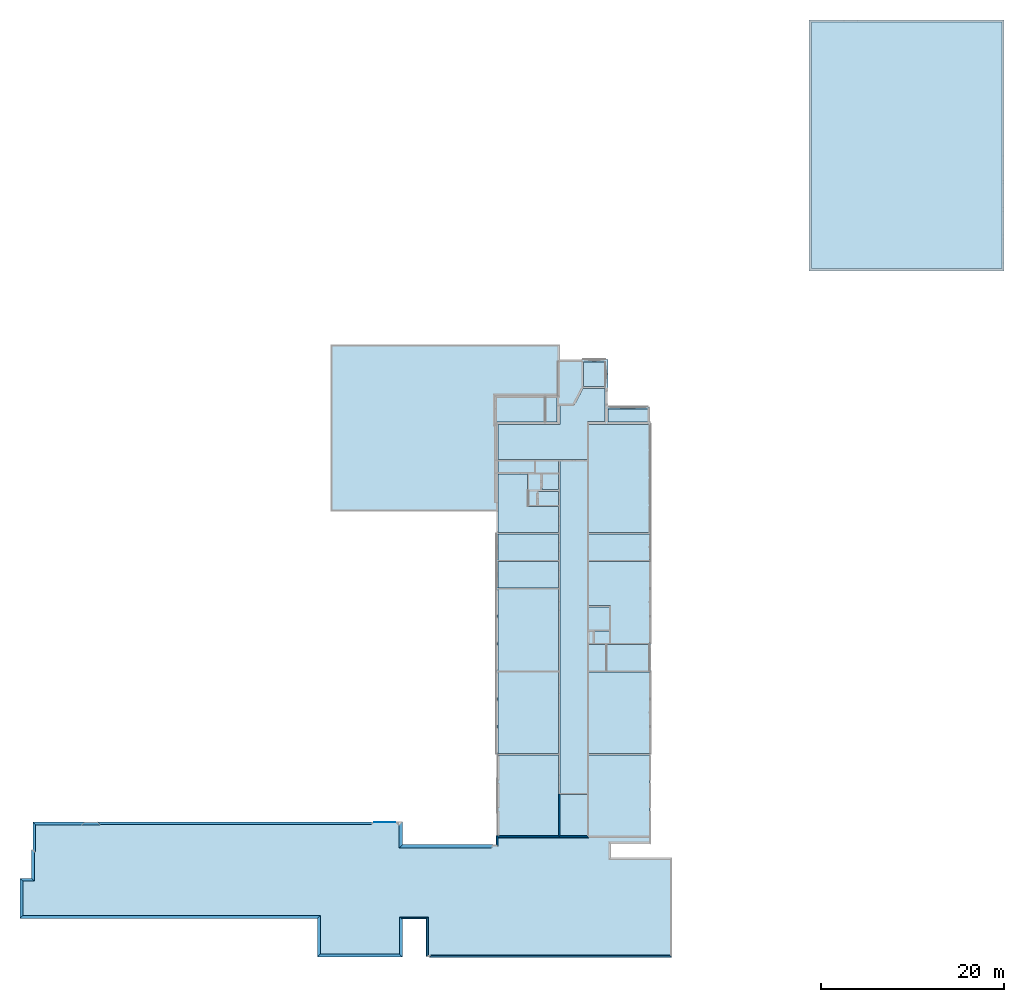
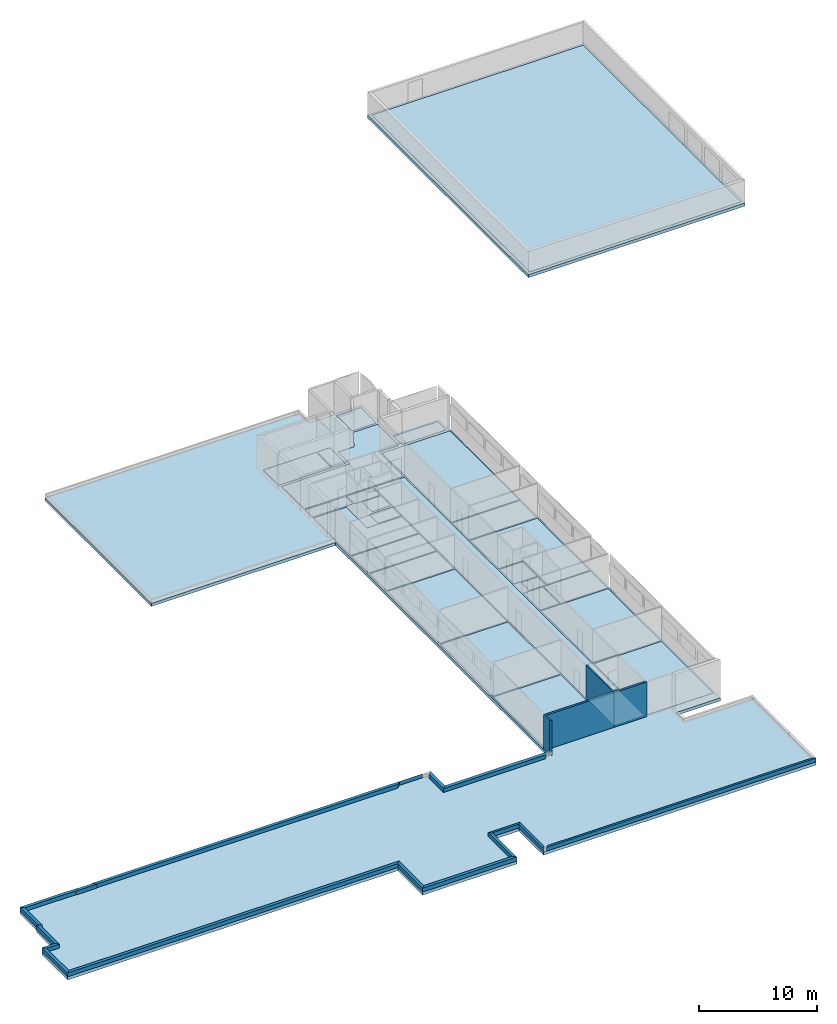
# One storey, part 1 of 72: 29 slabs, 21 walls.
"""IFC2X3 building model written with IfcOpenShell, lengths in metres."""

from ifc_helpers import new_model, entity, si_unit, converted_unit, derived_unit, frame, origin_with_axes, place, context, project, spatial, polyline, outline, extrude, material, layer, layer_set, layer_usage, element, save


model = new_model("IFC2X3")

# Units and contexts
context_of_model_1 = context(None, 3, world=origin_with_axes())
context_of_model_2 = context(None, 3, world=origin_with_axes())
context_of_model_3 = context(None, 2, world=origin_with_axes())
context_of_model_4 = context(None, 3, world=origin_with_axes())
ifc_project = project(units=[si_unit("LENGTHUNIT", "METRE"), si_unit("AREAUNIT", "SQUARE_METRE"), si_unit("ELECTRICCURRENTUNIT", "AMPERE"), si_unit("ELECTRICVOLTAGEUNIT", "VOLT"), si_unit("ELECTRICRESISTANCEUNIT", "OHM"), si_unit("POWERUNIT", "WATT"), si_unit("MASSUNIT", "GRAM"), si_unit("SOLIDANGLEUNIT", "STERADIAN"), si_unit("THERMODYNAMICTEMPERATUREUNIT", "KELVIN"), si_unit("PRESSUREUNIT", "PASCAL"), si_unit("LUMINOUSFLUXUNIT", "LUMEN"), si_unit("ILLUMINANCEUNIT", "LUX"), si_unit("FREQUENCYUNIT", "HERTZ"), si_unit("VOLUMEUNIT", "CUBIC_METRE"), si_unit("TIMEUNIT", "SECOND"), derived_unit("VOLUMETRICFLOWRATEUNIT", [(si_unit("TIMEUNIT", "SECOND"), -1), (si_unit("VOLUMEUNIT", "CUBIC_METRE"), 1)]), derived_unit("THERMALTRANSMITTANCEUNIT", [(si_unit("AREAUNIT", "SQUARE_METRE"), -1), (si_unit("THERMODYNAMICTEMPERATUREUNIT", "KELVIN"), -1), (si_unit("POWERUNIT", "WATT"), 1)]), converted_unit("PLANEANGLEUNIT", "DEGREE", entity("IfcPlaneAngleMeasure", 57.29577951308232), si_unit("PLANEANGLEUNIT", "RADIAN"), dimensions=[0, 0, 0, 0, 0, 0, 0])], contexts=[context_of_model_1, context_of_model_2, context_of_model_3, context_of_model_4])

# Site, building, storey
site = spatial("IfcSite", under=ifc_project, CompositionType="ELEMENT")
building_placement = place(None, origin_with_axes())
building = spatial("IfcBuilding", under=site, at=building_placement, Name="200", CompositionType="ELEMENT")
storey_placement = place(building_placement, frame((0.0, 0.0, 15.68000030517578), z_axis=(0.0, 0.0, 1.0), x_axis=(1.0, 0.0, 0.0)))
storey = spatial("IfcBuildingStorey", under=building, at=storey_placement, Name="3.etasje", CompositionType="ELEMENT", Elevation=15.68000030517578)

# Slabs
ifc_material_1 = material()
ifc_layer_1 = layer(ifc_material_1, 0.3199999928474426, ventilated=False)
ifc_layer_set_1 = layer_set([ifc_layer_1])
ifc_layer_usage_1 = layer_usage(ifc_layer_set_1, "AXIS2", "POSITIVE", 0.0)
slab_1_placement = place(storey_placement, frame((-58.36853408813477, -7.903265953063965, 0.0), z_axis=(0.0, 0.0, 1.0), x_axis=(1.0, 0.0, 0.0)))
element("IfcSlab", 1, at=slab_1_placement, inside=storey, material=ifc_layer_usage_1, PredefinedType="FLOOR", context=context_of_model_1, shape_type="SweptSolid", body=[
    extrude(outline(polyline([(0.0, 0.0), (32.4499683380127, 0.0), (32.4499683380127, 4.209481239318848), (41.70177268981934, 4.209481239318848), (41.70177268981934, 0.05925798416137695), (44.29998588562012, 0.05925798416137695), (44.29998588562012, 4.212923049926758), (44.60677242279053, 4.212923049926758), (44.60677242279053, 4.225009918212891), (71.1047716140747, 4.225009918212891), (71.1047716140747, -6.02961003780365), (71.10776233673096, -6.02961003780365), (71.10776233673096, -6.585259556770325), (64.40792465209961, -6.585260152816773), (64.40792465209961, -8.084145158529282), (68.78375244140625, -8.084145188331604), (68.78375053405762, -54.1521520614624), (68.66315460205078, -54.1521520614624), (68.66315460205078, -55.77051067352295), (64.11681985855103, -55.77051067352295), (64.11681985855103, -56.09284114837647), (64.06531953811646, -56.09284114837647), (64.06531953811646, -57.47471904754639), (64.11681985855103, -57.47471904754639), (64.11681985855103, -60.95492458343506), (61.24451804161072, -60.95492458343506), (61.24451804161072, -60.90466594696045), (58.8724530339241, -60.90466594696045), (58.87245297431946, -62.5457181930542), (33.87760543823242, -62.5457181930542), (33.87760543823242, -44.41311931610107), (51.95682668685913, -44.41311931610107), (51.95682525634766, -8.0008485019207), (51.5953369140625, -8.000848539173603), (51.5953369140625, -8.037950992584229), (41.71035003662109, -8.03795014321804), (41.71035003662109, -10.50583124160767), (40.91106414794922, -10.50583124160767), (40.91106414794922, -10.49967169761658), (38.66120910644531, -10.49967193603516), (38.66120910644531, -10.50583744049072), (8.456047058105469, -10.50583481788635), (8.456047058105469, -10.45953464508057), (7.036052703857422, -10.45953488349915), (7.036052703857422, -10.50094890594482), (1.391067504882813, -10.50094938278198), (1.391067504882813, -7.502594858407974), (1.260189056396484, -7.502594858407974), (1.260189056396484, -4.355633974075317), (0.0, -4.355633974075317), (0.0, 0.0)])), frame((0.0, 0.0, 0.0), z_axis=(0.0, 0.0, -1.0), x_axis=(1.0, 0.0, 0.0)), (0.0, 0.0, 1.0), 0.3199999928474426),
])
slab_2_placement = place(storey_placement, frame((27.65441703796387, 62.69001007080078, 0.0), z_axis=(0.0, 0.0, 1.0), x_axis=(1.0, 0.0, 0.0)))
element("IfcSlab", 2, at=slab_2_placement, inside=storey, material=ifc_layer_usage_1, PredefinedType="FLOOR", context=context_of_model_1, shape_type="SweptSolid", body=[
    extrude(outline(polyline([(0.0, 0.0), (21.29314231872559, 0.0), (21.29314231872559, 27.37604522705078), (0.0, 27.37604522705078), (0.0, 0.0)])), origin_with_axes(), (0.0, 0.0, -1.0), 0.3199999928474426),
])
slab_3_placement = place(storey_placement, frame((5.74828577041626, 46.24888610839844, 0.0), z_axis=(0.0, 0.0, 1.0), x_axis=(1.0, 0.0, 0.0)))
element("IfcSlab", 3, at=slab_3_placement, inside=storey, material=ifc_layer_usage_1, PredefinedType="FLOOR", context=context_of_model_1, shape_type="SweptSolid", body=[
    extrude(outline(polyline([(0.0, 0.0), (4.346334934234619, 0.0), (4.346334934234619, 1.418357849121094), (0.0, 1.418357849121094), (0.0, 0.0)])), origin_with_axes(), (0.0, 0.0, 1.0), 0.01),
])
slab_4_placement = place(storey_placement, frame((-1.05615508556366, 46.24888610839844, 0.0), z_axis=(0.0, 0.0, 1.0), x_axis=(1.0, 0.0, 0.0)))
element("IfcSlab", 4, at=slab_4_placement, inside=storey, material=ifc_layer_usage_1, PredefinedType="FLOOR", context=context_of_model_1, shape_type="SweptSolid", body=[
    extrude(outline(polyline([(0.0, 0.0), (1.258574590086937, 0.0), (1.258574590086937, 2.633838653564453), (0.0, 2.633838653564453), (0.0, 0.0)])), origin_with_axes(), (0.0, 0.0, 1.0), 0.01),
])
slab_5_placement = place(storey_placement, frame((27.95441627502441, 62.99000930786133, 0.0), z_axis=(0.0, 0.0, 1.0), x_axis=(1.0, 0.0, 0.0)))
element("IfcSlab", 5, at=slab_5_placement, inside=storey, material=ifc_layer_usage_1, PredefinedType="FLOOR", context=context_of_model_1, shape_type="SweptSolid", body=[
    extrude(outline(polyline([(0.0, 0.0), (20.76314735412598, 0.0), (20.76314735412598, 26.85060501098633), (0.0, 26.85060501098633), (0.0, 0.0)])), origin_with_axes(), (0.0, 0.0, 1.0), 0.01),
])
slab_6_placement = place(storey_placement, frame((-6.382164001464844, 46.24888610839844, 0.0), z_axis=(0.0, 0.0, 1.0), x_axis=(1.0, 0.0, 0.0)))
element("IfcSlab", 6, at=slab_6_placement, inside=storey, material=ifc_layer_usage_1, PredefinedType="FLOOR", context=context_of_model_1, shape_type="SweptSolid", body=[
    extrude(outline(polyline([(0.0, 0.0), (5.229906320571899, 0.0), (5.229906320571899, 2.633838653564453), (0.0, 2.633838653564453), (0.0, 0.0)])), origin_with_axes(), (0.0, 0.0, 1.0), 0.01),
])
slab_7_placement = place(storey_placement, frame((3.637814044952393, 1.092785239219666, 0.0), z_axis=(0.0, 0.0, 1.0), x_axis=(1.0, 0.0, 0.0)))
element("IfcSlab", 7, at=slab_7_placement, inside=storey, material=ifc_layer_usage_1, PredefinedType="FLOOR", context=context_of_model_1, shape_type="SweptSolid", body=[
    extrude(outline(polyline([(0.0, 0.0), (6.62665605545044, 0.0), (6.62665605545044, 8.8333021402359), (0.0, 8.8333021402359), (0.0, 0.0)])), origin_with_axes(), (0.0, 0.0, 1.0), 0.01),
])
slab_8_placement = place(storey_placement, frame((3.637814283370972, 10.04668712615967, 0.0), z_axis=(0.0, 0.0, 1.0), x_axis=(1.0, 0.0, 0.0)))
element("IfcSlab", 8, at=slab_8_placement, inside=storey, material=ifc_layer_usage_1, PredefinedType="FLOOR", context=context_of_model_1, shape_type="SweptSolid", body=[
    extrude(outline(polyline([(0.0, 0.0), (6.62665581703186, 0.0), (6.62665581703186, 8.921465873718262), (0.0, 8.921465873718262), (0.0, 0.0)])), origin_with_axes(), (0.0, 0.0, 1.0), 0.01),
])
slab_9_placement = place(storey_placement, frame((5.647815704345703, 19.08875274658203, 0.0), z_axis=(0.0, 0.0, 1.0), x_axis=(1.0, 0.0, 0.0)))
element("IfcSlab", 9, at=slab_9_placement, inside=storey, material=ifc_layer_usage_1, PredefinedType="FLOOR", context=context_of_model_1, shape_type="SweptSolid", body=[
    extrude(outline(polyline([(0.0, 0.0), (4.616654396057129, 0.0), (4.616654396057129, 2.879892349243164), (0.0, 2.879892349243164), (0.0, 0.0)])), origin_with_axes(), (0.0, 0.0, 1.0), 0.01),
])
slab_10_placement = place(storey_placement, frame((3.637814521789551, 19.08875274658203, 0.0), z_axis=(0.0, 0.0, 1.0), x_axis=(1.0, 0.0, 0.0)))
element("IfcSlab", 10, at=slab_10_placement, inside=storey, material=ifc_layer_usage_1, PredefinedType="FLOOR", context=context_of_model_1, shape_type="SweptSolid", body=[
    extrude(outline(polyline([(0.0, 0.0), (1.909500122070313, 0.0), (1.909500122070313, 2.879892349243164), (0.0, 2.879892349243164), (0.0, 0.0)])), origin_with_axes(), (0.0, 0.0, 1.0), 0.01),
])
slab_11_placement = place(storey_placement, frame((6.037815093994141, 22.08924674987793, 0.0), z_axis=(0.0, 0.0, 1.0), x_axis=(1.0, 0.0, 0.0)))
element("IfcSlab", 11, at=slab_11_placement, inside=storey, material=ifc_layer_usage_1, PredefinedType="FLOOR", context=context_of_model_1, shape_type="SweptSolid", body=[
    extrude(outline(polyline([(0.0, 0.0), (4.226655006408691, 0.0), (4.226655006408691, 8.93182373046875), (-2.400000333786011, 8.93182373046875), (-2.400000333786011, 4.099998474121094), (0.0, 4.099998474121094), (0.0, 0.0)])), origin_with_axes(), (0.0, 0.0, 1.0), 0.01),
])
slab_12_placement = place(storey_placement, frame((4.310362815856934, 22.08924674987793, 0.0), z_axis=(0.0, 0.0, 1.0), x_axis=(1.0, 0.0, 0.0)))
element("IfcSlab", 12, at=slab_12_placement, inside=storey, material=ifc_layer_usage_1, PredefinedType="FLOOR", context=context_of_model_1, shape_type="SweptSolid", body=[
    extrude(outline(polyline([(0.0, 0.0), (1.603451728820801, 0.0), (1.603451728820801, 1.352142333984375), (0.0, 1.352142333984375), (0.0, 0.0)])), origin_with_axes(), (0.0, 0.0, 1.0), 0.01),
])
slab_13_placement = place(storey_placement, frame((3.637814521789551, 23.56538772583008, 0.0), z_axis=(0.0, 0.0, 1.0), x_axis=(1.0, 0.0, 0.0)))
element("IfcSlab", 13, at=slab_13_placement, inside=storey, material=ifc_layer_usage_1, PredefinedType="FLOOR", context=context_of_model_1, shape_type="SweptSolid", body=[
    extrude(outline(polyline([(0.0, 0.0), (2.276000022888184, 0.0), (2.276000022888184, 2.499856948852539), (0.0, 2.499856948852539), (0.0, 0.0)])), origin_with_axes(), (0.0, 0.0, 1.0), 0.01),
])
slab_14_placement = place(storey_placement, frame((3.63781476020813, 31.14167213439941, 0.0), z_axis=(0.0, 0.0, 1.0), x_axis=(1.0, 0.0, 0.0)))
element("IfcSlab", 14, at=slab_14_placement, inside=storey, material=ifc_layer_usage_1, PredefinedType="FLOOR", context=context_of_model_1, shape_type="SweptSolid", body=[
    extrude(outline(polyline([(0.0, 0.0), (6.626655340194702, 0.0), (6.626655340194702, 2.893617630004883), (0.0, 2.893617630004883), (0.0, 0.0)])), origin_with_axes(), (0.0, 0.0, 1.0), 0.01),
])
slab_15_placement = place(storey_placement, frame((3.63781476020813, 34.16091156005859, 0.0), z_axis=(0.0, 0.0, 1.0), x_axis=(1.0, 0.0, 0.0)))
element("IfcSlab", 15, at=slab_15_placement, inside=storey, material=ifc_layer_usage_1, PredefinedType="FLOOR", context=context_of_model_1, shape_type="SweptSolid", body=[
    extrude(outline(polyline([(0.0, 0.0), (6.676905393600464, 0.0), (6.676905393600464, 11.81662750244141), (0.0, 11.81662750244141), (0.0, 0.0)])), origin_with_axes(), (0.0, 0.0, 1.0), 0.01),
])
slab_16_placement = place(storey_placement, frame((-2.141367912292481, 40.66753387451172, 0.0), z_axis=(0.0, 0.0, 1.0), x_axis=(1.0, 0.0, 0.0)))
element("IfcSlab", 16, at=slab_16_placement, inside=storey, material=ifc_layer_usage_1, PredefinedType="FLOOR", context=context_of_model_1, shape_type="SweptSolid", body=[
    extrude(outline(polyline([(0.0, 0.0), (2.525595724582672, 0.0), (2.525595724582672, 1.294193267822266), (0.0, 1.294193267822266), (0.0, 0.0)])), origin_with_axes(), (0.0, 0.0, 1.0), 0.01),
])
slab_17_placement = place(storey_placement, frame((-2.880736112594605, 38.88173294067383, 0.0), z_axis=(0.0, 0.0, 1.0), x_axis=(1.0, 0.0, 0.0)))
element("IfcSlab", 17, at=slab_17_placement, inside=storey, material=ifc_layer_usage_1, PredefinedType="FLOOR", context=context_of_model_1, shape_type="SweptSolid", body=[
    extrude(outline(polyline([(0.0, 0.0), (3.264963835477829, 0.0), (3.264963835477829, 1.665203094482422), (1.439915895462036, 1.665203094482422), (1.439915895462036, 0.0), (1.319316625595093, 0.0), (1.319316625595093, 1.665203094482422), (0.0, 1.665203094482422), (0.0, 0.0)])), origin_with_axes(), (0.0, 0.0, 1.0), 0.01),
])
slab_18_placement = place(storey_placement, frame((-2.880736112594605, 37.13524627685547, 0.0), z_axis=(0.0, 0.0, 1.0), x_axis=(1.0, 0.0, 0.0)))
element("IfcSlab", 18, at=slab_18_placement, inside=storey, material=ifc_layer_usage_1, PredefinedType="FLOOR", context=context_of_model_1, shape_type="SweptSolid", body=[
    extrude(outline(polyline([(0.0, 0.0), (0.9046808481216431, 0.0), (0.9046808481216431, 1.520359039306641), (1.025281190872192, 1.520359039306641), (1.025281190872192, 0.0), (3.264963805675507, 0.0), (3.264963805675507, 1.520359039306641), (0.0, 1.520359039306641), (0.0, 0.0)])), origin_with_axes(), (0.0, 0.0, 1.0), 0.01),
])
slab_19_placement = place(storey_placement, frame((-6.245882034301758, 34.16127777099609, 0.0), z_axis=(0.0, 0.0, 1.0), x_axis=(1.0, 0.0, 0.0)))
element("IfcSlab", 19, at=slab_19_placement, inside=storey, material=ifc_layer_usage_1, PredefinedType="FLOOR", context=context_of_model_1, shape_type="SweptSolid", body=[
    extrude(outline(polyline([(0.0, 0.0), (6.630109637975693, 0.0), (6.630109637975693, 2.853366851806641), (3.250484704971314, 2.853366851806641), (3.250484704971314, 6.406261444091797), (0.0, 6.406261444091797), (0.0, 0.0)])), origin_with_axes(), (0.0, 0.0, 1.0), 0.01),
])
slab_20_placement = place(storey_placement, frame((-6.245882034301758, 40.71953582763672, 0.0), z_axis=(0.0, 0.0, 1.0), x_axis=(1.0, 0.0, 0.0)))
element("IfcSlab", 20, at=slab_20_placement, inside=storey, material=ifc_layer_usage_1, PredefinedType="FLOOR", context=context_of_model_1, shape_type="SweptSolid", body=[
    extrude(outline(polyline([(0.0, 0.0), (3.983913898468018, 0.0), (3.983913898468018, 1.242191314697266), (0.0, 1.242191314697266), (0.0, 0.0)])), origin_with_axes(), (0.0, 0.0, 1.0), 0.01),
])
slab_21_placement = place(storey_placement, frame((-6.245882511138916, 31.14223098754883, 0.0), z_axis=(0.0, 0.0, 1.0), x_axis=(1.0, 0.0, 0.0)))
element("IfcSlab", 21, at=slab_21_placement, inside=storey, material=ifc_layer_usage_1, PredefinedType="FLOOR", context=context_of_model_1, shape_type="SweptSolid", body=[
    extrude(outline(polyline([(0.0, 0.0), (6.630110114812851, 0.0), (6.630110114812851, 2.893424987792969), (0.0, 2.893424987792969), (0.0, 0.0)])), origin_with_axes(), (0.0, 0.0, 1.0), 0.01),
])
slab_22_placement = place(storey_placement, frame((-6.245882511138916, 28.11410903930664, 0.0), z_axis=(0.0, 0.0, 1.0), x_axis=(1.0, 0.0, 0.0)))
element("IfcSlab", 22, at=slab_22_placement, inside=storey, material=ifc_layer_usage_1, PredefinedType="FLOOR", context=context_of_model_1, shape_type="SweptSolid", body=[
    extrude(outline(polyline([(0.0, 0.0), (6.630110055208206, 0.0), (6.630110055208206, 2.907522201538086), (0.0, 2.907522201538086), (0.0, 0.0)])), origin_with_axes(), (0.0, 0.0, 1.0), 0.01),
])
slab_23_placement = place(storey_placement, frame((-6.245882511138916, 19.08161354064941, 0.0), z_axis=(0.0, 0.0, 1.0), x_axis=(1.0, 0.0, 0.0)))
element("IfcSlab", 23, at=slab_23_placement, inside=storey, material=ifc_layer_usage_1, PredefinedType="FLOOR", context=context_of_model_1, shape_type="SweptSolid", body=[
    extrude(outline(polyline([(0.0, 0.0), (6.630109965801239, 0.0), (6.630109965801239, 8.911895751953125), (0.0, 8.911895751953125), (0.0, 0.0)])), origin_with_axes(), (0.0, 0.0, 1.0), 0.01),
])
slab_24_placement = place(storey_placement, frame((-6.245882987976074, 10.04668712615967, 0.0), z_axis=(0.0, 0.0, 1.0), x_axis=(1.0, 0.0, 0.0)))
element("IfcSlab", 24, at=slab_24_placement, inside=storey, material=ifc_layer_usage_1, PredefinedType="FLOOR", context=context_of_model_1, shape_type="SweptSolid", body=[
    extrude(outline(polyline([(0.0, 0.0), (6.630110234022141, 0.0), (6.630110234022141, 8.909300804138184), (0.0, 8.909300804138184), (0.0, 0.0)])), origin_with_axes(), (0.0, 0.0, 1.0), 0.01),
])
slab_25_placement = place(storey_placement, frame((-6.245882987976074, 1.092785477638245, 0.0), z_axis=(0.0, 0.0, 1.0), x_axis=(1.0, 0.0, 0.0)))
element("IfcSlab", 25, at=slab_25_placement, inside=storey, material=ifc_layer_usage_1, PredefinedType="FLOOR", context=context_of_model_1, shape_type="SweptSolid", body=[
    extrude(outline(polyline([(0.0, 0.0), (6.630110025405884, 0.0), (6.630110025405884, 8.833301901817322), (0.0, 8.833301901817322), (0.0, 0.0)])), origin_with_axes(), (0.0, 0.0, 1.0), 0.01),
])
slab_26_placement = place(storey_placement, frame((0.5048271417617798, 5.72745943069458, 0.0), z_axis=(0.0, 0.0, 1.0), x_axis=(1.0, 0.0, 0.0)))
element("IfcSlab", 26, at=slab_26_placement, inside=storey, material=ifc_layer_usage_1, PredefinedType="FLOOR", context=context_of_model_1, shape_type="SweptSolid", body=[
    extrude(outline(polyline([(0.0, 0.0), (3.012388348579407, 0.0), (3.012388348579407, 36.2342677116394), (0.0, 36.2342677116394), (0.0, 0.0)])), origin_with_axes(), (0.0, 0.0, 1.0), 0.01),
])
slab_27_placement = place(storey_placement, frame((0.505363941192627, 1.092785358428955, 0.0), z_axis=(0.0, 0.0, 1.0), x_axis=(1.0, 0.0, 0.0)))
element("IfcSlab", 27, at=slab_27_placement, inside=storey, material=ifc_layer_usage_1, PredefinedType="FLOOR", context=context_of_model_1, shape_type="SweptSolid", body=[
    extrude(outline(polyline([(0.0, 0.0), (3.011851310729981, 0.0), (3.011851310729981, 4.514073848724365), (0.0, 4.514073848724365), (0.0, 0.0)])), origin_with_axes(), (0.0, 0.0, 1.0), 0.01),
])
slab_28_placement = place(storey_placement, frame((-6.245882034301758, 42.11247634887695, 0.0), z_axis=(0.0, 0.0, 1.0), x_axis=(1.0, 0.0, 0.0)))
element("IfcSlab", 28, at=slab_28_placement, inside=storey, material=ifc_layer_usage_1, PredefinedType="FLOOR", context=context_of_model_1, shape_type="SweptSolid", body=[
    extrude(outline(polyline([(0.0, 0.0), (9.763098239898682, 0.0), (9.763098239898682, 4.164474487304688), (11.69266748428345, 4.164474487304688), (11.69266748428345, 7.775295257568359), (9.292309522628784, 7.775295257568359), (8.292407751083374, 5.892616271972656), (6.749600112438202, 5.892616271972656), (6.749600112438202, 3.865062713623047), (0.0, 3.865062713623047), (0.0, 0.0)])), origin_with_axes(), (0.0, 0.0, 1.0), 0.01),
])
slab_29_placement = place(storey_placement, frame((3.076985120773315, 50.09304428100586, 0.0), z_axis=(0.0, 0.0, 1.0), x_axis=(1.0, 0.0, 0.0)))
element("IfcSlab", 29, at=slab_29_placement, inside=storey, material=ifc_layer_usage_1, PredefinedType="FLOOR", context=context_of_model_1, shape_type="SweptSolid", body=[
    extrude(outline(polyline([(0.0, 0.0), (2.369800806045532, 0.0), (2.369800806045532, 2.657112121582031), (0.0, 2.657112121582031), (0.0, 0.0)])), origin_with_axes(), (0.0, 0.0, 1.0), 0.01),
])

# Walls
ifc_material_2 = material(Name="Layer-YV3 30 cm")
ifc_layer_2 = layer(ifc_material_2, 0.300000011920929, ventilated=False)
ifc_layer_set_2 = layer_set([ifc_layer_2])
ifc_layer_usage_2 = layer_usage(ifc_layer_set_2, "AXIS2", "POSITIVE", 0.0)
wall_1_placement = place(storey_placement, frame((-58.36853408813477, -7.903265953063965, 0.0), z_axis=(0.0, 0.0, 1.0), x_axis=(1.0, 0.0, 0.0)))
element("IfcWallStandardCase", 30, at=wall_1_placement, inside=storey, material=ifc_layer_usage_2, Name="YV3 30 cm", context=context_of_model_1, shape_type="SweptSolid", body=[
    extrude(outline(polyline([(0.0, 0.0), (32.4499683380127, 0.0), (32.74996948242188, 0.3000001907348633), (0.2999992370605469, 0.3000001907348633), (0.0, 0.0)])), origin_with_axes(), (0.0, 0.0, 1.0), 0.4),
])
wall_2_placement = place(storey_placement, frame((-25.91856575012207, -7.903265953063965, 0.0), z_axis=(0.0, 0.0, 1.0), x_axis=(-4.371138828673793e-08, -1.0, 0.0)))
element("IfcWallStandardCase", 31, at=wall_2_placement, inside=storey, material=ifc_layer_usage_2, Name="YV3 30 cm", context=context_of_model_1, shape_type="SweptSolid", body=[
    extrude(outline(polyline([(0.0, 0.0), (4.209481239318849, 0.0), (3.909481048583984, 0.2999992370605474), (-0.3000001907348632, 0.2999973297119146), (0.0, 0.0)])), frame((0.0, 0.0, 0.0), z_axis=(0.0, 0.0, 1.0), x_axis=(0.9999999999999989, 4.371138966755488e-08, 0.0)), (0.0, 0.0, 1.0), 0.4),
])
wall_3_placement = place(storey_placement, frame((-25.91856575012207, -12.11274719238281, 0.0), z_axis=(0.0, 0.0, 1.0), x_axis=(1.0, 0.0, 0.0)))
element("IfcWallStandardCase", 32, at=wall_3_placement, inside=storey, material=ifc_layer_usage_2, Name="YV3 30 cm", context=context_of_model_1, shape_type="SweptSolid", body=[
    extrude(outline(polyline([(0.0, 0.0), (9.25180435180664, 0.0), (8.951805114746094, 0.3000001907348633), (0.2999992370605469, 0.3000001907348633), (0.0, 0.0)])), origin_with_axes(), (0.0, 0.0, 1.0), 0.4),
])
wall_4_placement = place(storey_placement, frame((-16.66676139831543, -12.11274719238281, 0.0), z_axis=(0.0, 0.0, 1.0), x_axis=(-4.371138828673793e-08, 1.0, 0.0)))
element("IfcWallStandardCase", 33, at=wall_4_placement, inside=storey, material=ifc_layer_usage_2, Name="YV3 30 cm", context=context_of_model_1, shape_type="SweptSolid", body=[
    extrude(outline(polyline([(0.0, 0.0), (4.150223255157471, 0.0), (4.350223064422607, 0.2999992370605477), (0.3000001907348642, 0.2999992370605474), (0.0, 0.0)])), frame((0.0, 0.0, 0.0), z_axis=(0.0, 0.0, 1.0), x_axis=(0.9999999999999989, -4.371138986525872e-08, 0.0)), (0.0, 0.0, 1.0), 0.4),
])
ifc_material_3 = material(Name="Layer-YV04 20 cm")
ifc_layer_3 = layer(ifc_material_3, 0.2000000029802322, ventilated=False)
ifc_layer_set_3 = layer_set([ifc_layer_3])
ifc_layer_usage_3 = layer_usage(ifc_layer_set_3, "AXIS2", "POSITIVE", 0.0)
wall_5_placement = place(storey_placement, frame((-16.66676139831543, -7.962523937225342, 0.0), z_axis=(0.0, 0.0, 1.0), x_axis=(1.0, 0.0, 0.0)))
element("IfcWallStandardCase", 34, at=wall_5_placement, inside=storey, material=ifc_layer_usage_3, Name="YV04 20 cm", context=context_of_model_1, shape_type="SweptSolid", body=[
    extrude(outline(polyline([(0.0, 0.0), (2.598213195800781, 0.0), (2.798213005065918, 0.1999998092651367), (-0.2999992370605469, 0.1999998092651367), (0.0, 0.0)])), origin_with_axes(), (0.0, 0.0, 1.0), 0.4),
])
wall_6_placement = place(storey_placement, frame((-14.06854820251465, -7.962523937225342, 0.0), z_axis=(0.0, 0.0, 1.0), x_axis=(-4.371138828673793e-08, -1.0, 0.0)))
element("IfcWallStandardCase", 35, at=wall_6_placement, inside=storey, material=ifc_layer_usage_3, Name="YV04 20 cm", context=context_of_model_1, shape_type="SweptSolid", body=[
    extrude(outline(polyline([(0.0, 0.0), (4.153665065765381, 0.0), (3.953665256500244, 0.1999998092651375), (-0.1999998092651373, 0.1999998092651375), (0.0, 0.0)])), frame((0.0, 0.0, 0.0), z_axis=(0.0, 0.0, 1.0), x_axis=(0.9999999999999989, 4.371138997138944e-08, 0.0)), (0.0, 0.0, 1.0), 0.4),
])
wall_7_placement = place(storey_placement, frame((-13.76176166534424, -12.12827587127686, 0.0), z_axis=(0.0, 0.0, 1.0), x_axis=(1.0, 0.0, 0.0)))
element("IfcWallStandardCase", 36, at=wall_7_placement, inside=storey, material=ifc_layer_usage_3, Name="YV04 20 cm", context=context_of_model_1, shape_type="SweptSolid", body=[
    extrude(outline(polyline([(0.0, 0.0), (26.49799919128418, 0.0), (26.29800033569336, 0.1999998092651367), (0.1999998092651367, 0.1999998092651367), (0.0, 0.0)])), origin_with_axes(), (0.0, 0.0, 1.0), 0.4),
])
ifc_material_4 = material(Name="Layer-YV3 15 cm")
ifc_layer_4 = layer(ifc_material_4, 0.166, ventilated=False)
ifc_layer_set_4 = layer_set([ifc_layer_4])
ifc_layer_usage_4 = layer_usage(ifc_layer_set_4, "AXIS2", "POSITIVE", 0.0)
wall_8_placement = place(storey_placement, frame((-6.411708831787109, 1.092785835266113, 0.0), z_axis=(0.0, 0.0, 1.0), x_axis=(-4.371138828673793e-08, -1.0, 0.0)))
element("IfcWallStandardCase", 37, at=wall_8_placement, inside=storey, material=ifc_layer_usage_4, Name="YV3 15 cm", context=context_of_model_1, shape_type="SweptSolid", body=[
    extrude(outline(polyline([(0.0, 0.0), (0.9952032864093783, 6.617444900424221e-24), (1.145203351974487, 0.1659998893737798), (1.204359288532794e-16, 0.1659998893737795), (0.0, 0.0)])), frame((0.0, 0.0, 0.0), z_axis=(0.0, 0.0, 1.0), x_axis=(0.999999999999999, 4.371138968871943e-08, 0.0)), (0.0, 0.0, 1.0), 3.6),
])
ifc_material_5 = material(Name="Layer-Yttervegg 35 cm")
ifc_layer_5 = layer(ifc_material_5, 0.3499999940395355, ventilated=False)
ifc_layer_set_5 = layer_set([ifc_layer_5], Name="ML-Yttervegg 35 cm - 0.350")
ifc_layer_usage_5 = layer_usage(ifc_layer_set_5, "AXIS2", "POSITIVE", 0.0)
wall_9_placement = place(storey_placement, frame((-6.773197174072266, 0.1346850395202637, 0.0), z_axis=(0.0, 0.0, 1.0), x_axis=(-1.0, -1.509958025280866e-07, 0.0)))
element("IfcWallStandardCase", 38, at=wall_9_placement, inside=storey, material=ifc_layer_usage_5, Name="Yttervegg 35 cm", context=context_of_model_1, shape_type="SweptSolid", body=[
    extrude(outline(polyline([(0.0, 0.0), (9.884986877441442, 0.0), (10.23498728898487, 0.3499999788669591), (0.1500001254411353, 0.3499999960519571), (0.0, 0.0)])), frame((0.0, 0.0, 0.0), z_axis=(0.0, 0.0, 1.0), x_axis=(0.9999999999999979, -6.507093156297758e-08, 0.0)), (0.0, 0.0, 1.0), 0.4),
])
wall_10_placement = place(storey_placement, frame((-16.65818405151367, 0.1346841901540756, 0.0), z_axis=(0.0, 0.0, 1.0), x_axis=(-4.371138828673793e-08, 1.0, 0.0)))
element("IfcWallStandardCase", 39, at=wall_10_placement, inside=storey, material=ifc_layer_usage_5, Name="Yttervegg 35 cm", context=context_of_model_1, shape_type="SweptSolid", body=[
    extrude(outline(polyline([(0.0, 0.0), (2.467881098389625, -1.323488980084844e-23), (2.117881193757057, 0.350000381469728), (-0.3500000238418579, 0.3500003814697263), (0.0, 0.0)])), frame((0.0, 0.0, 0.0), z_axis=(0.0, 0.0, 1.0), x_axis=(0.9999999999999991, -4.371138988355713e-08, 0.0)), (0.0, 0.0, 1.0), 0.4),
])
ifc_material_6 = material(Name="Layer-Yttervegg 10 cm")
ifc_layer_6 = layer(ifc_material_6, 0.009999999776482582, ventilated=False)
ifc_layer_set_6 = layer_set([ifc_layer_6], Name="ML-Yttervegg 10 cm - 0.010")
ifc_layer_usage_6 = layer_usage(ifc_layer_set_6, "AXIS2", "POSITIVE", 0.0)
wall_11_placement = place(storey_placement, frame((-17.45746994018555, 2.596405744552612, 0.0), z_axis=(0.0, 0.0, 1.0), x_axis=(-1.0, 1.509958025280866e-07, 0.0)))
element("IfcWallStandardCase", 40, at=wall_11_placement, inside=storey, material=ifc_layer_usage_6, Name="Yttervegg 10 cm", context=context_of_model_1, shape_type="SweptSolid", body=[
    extrude(outline(polyline([(0.0, 0.0), (2.249855041503919, 0.0), (2.249855040444214, 0.009999990463256893), (-1.059705444488938e-09, 0.009999990463256893), (0.0, 0.0)])), frame((0.0, 0.0, 0.0), z_axis=(0.0, 0.0, 1.0), x_axis=(0.999999999999999, 4.502515890998319e-08, 0.0)), (0.0, 0.0, 1.0), 0.4),
])
wall_12_placement = place(storey_placement, frame((-19.70732498168945, 2.602571487426758, 0.0), z_axis=(0.0, 0.0, 1.0), x_axis=(-1.0, -1.509958025280866e-07, 0.0)))
element("IfcWallStandardCase", 41, at=wall_12_placement, inside=storey, material=ifc_layer_usage_2, Name="YV3 30 cm", context=context_of_model_1, shape_type="SweptSolid", body=[
    extrude(outline(polyline([(0.0, 0.0), (30.20516204833996, 0.0), (29.90516283732731, 0.299999978364126), (0.2999992631084515, 0.2999999262684404), (0.0, 0.0)])), frame((0.0, 0.0, 0.0), z_axis=(0.0, 0.0, 1.0), x_axis=(0.999999999999998, -6.416943591541922e-08, 0.0)), (0.0, 0.0, 1.0), 0.4),
])
wall_13_placement = place(storey_placement, frame((-49.9124870300293, 2.556268692016602, 0.0), z_axis=(0.0, 0.0, 1.0), x_axis=(-1.0, 1.509958025280866e-07, 0.0)))
element("IfcWallStandardCase", 42, at=wall_13_placement, inside=storey, material=ifc_layer_usage_2, Name="YV3 30 cm", context=context_of_model_1, shape_type="SweptSolid", body=[
    extrude(outline(polyline([(0.0, 0.0), (1.419994354248061, 0.0), (1.719993540938291, 0.3000000026864747), (-0.2999992874308619, 0.2999999019460849), (0.0, 0.0)])), frame((0.0, 0.0, 0.0), z_axis=(0.0, 0.0, 1.0), x_axis=(0.9999999999999999, -1.690527652716697e-08, 0.0)), (0.0, 0.0, 1.0), 0.4),
])
wall_14_placement = place(storey_placement, frame((-51.33248138427734, 2.597682952880859, 0.0), z_axis=(0.0, 0.0, 1.0), x_axis=(-1.0, 1.509958025280866e-07, 0.0)))
element("IfcWallStandardCase", 43, at=wall_14_placement, inside=storey, material=ifc_layer_usage_2, Name="YV3 30 cm", context=context_of_model_1, shape_type="SweptSolid", body=[
    extrude(outline(polyline([(0.0, 0.0), (5.644985198974629, 0.0), (5.344985936572811, 0.2999999269750677), (0.2999992117192727, 0.2999999776574983), (0.0, 0.0)])), frame((0.0, 0.0, 0.0), z_axis=(0.0, 0.0, 1.0), x_axis=(0.9999999999999978, 6.652486763043437e-08, 0.0)), (0.0, 0.0, 1.0), 0.4),
])
wall_15_placement = place(storey_placement, frame((-56.97746658325195, 2.597683429718018, 0.0), z_axis=(0.0, 0.0, 1.0), x_axis=(-4.371138828673793e-08, -1.0, 0.0)))
element("IfcWallStandardCase", 44, at=wall_15_placement, inside=storey, material=ifc_layer_usage_2, Name="YV3 30 cm", context=context_of_model_1, shape_type="SweptSolid", body=[
    extrude(outline(polyline([(0.0, 0.0), (2.998354524374009, 2.646977960169689e-23), (3.298354625701904, 0.2999992370605473), (0.299999952316284, 0.2999992370605467), (0.0, 0.0)])), frame((0.0, 0.0, 0.0), z_axis=(0.0, 0.0, 1.0), x_axis=(0.999999999999999, 4.37113899170623e-08, 0.0)), (0.0, 0.0, 1.0), 0.4),
])
wall_16_placement = place(storey_placement, frame((-57.10834503173828, -0.4006710946559906, 0.0), z_axis=(0.0, 0.0, 1.0), x_axis=(-4.371138828673793e-08, -1.0, 0.0)))
element("IfcWallStandardCase", 45, at=wall_16_placement, inside=storey, material=ifc_layer_usage_2, Name="YV3 30 cm", context=context_of_model_1, shape_type="SweptSolid", body=[
    extrude(outline(polyline([(0.0, 0.0), (3.146960884332657, 0.0), (3.446960836648941, 0.2999992370605468), (0.2999999821186065, 0.2999992370605455), (0.0, 0.0)])), frame((0.0, 0.0, 0.0), z_axis=(0.0, 0.0, 1.0), x_axis=(0.999999999999999, 4.37113893614273e-08, 0.0)), (0.0, 0.0, 1.0), 0.4),
])
wall_17_placement = place(storey_placement, frame((-57.10834503173828, -3.547631978988648, 0.0), z_axis=(0.0, 0.0, 1.0), x_axis=(-1.0, -8.742277657347586e-08, 0.0)))
element("IfcWallStandardCase", 46, at=wall_17_placement, inside=storey, material=ifc_layer_usage_2, Name="YV3 30 cm", context=context_of_model_1, shape_type="SweptSolid", body=[
    extrude(outline(polyline([(0.0, 0.0), (1.260189056396482, -1.323488980084844e-23), (0.9601898193359402, 0.2999999523162842), (-0.2999992370605426, 0.2999997138977051), (0.0, 0.0)])), frame((0.0, 0.0, 0.0), z_axis=(0.0, 0.0, 1.0), x_axis=(0.9999999999999961, -8.74227799931475e-08, 0.0)), (0.0, 0.0, 1.0), 0.4),
])
wall_18_placement = place(storey_placement, frame((-58.36853408813477, -3.547631978988648, 0.0), z_axis=(0.0, 0.0, 1.0), x_axis=(-4.371138828673793e-08, -1.0, 0.0)))
element("IfcWallStandardCase", 47, at=wall_18_placement, inside=storey, material=ifc_layer_usage_2, Name="YV3 30 cm", context=context_of_model_1, shape_type="SweptSolid", body=[
    extrude(outline(polyline([(0.0, 0.0), (4.355633974075317, 0.0), (4.055633783340454, 0.299999237060551), (0.2999999523162839, 0.2999992370605467), (0.0, 0.0)])), frame((0.0, 0.0, 0.0), z_axis=(0.0, 0.0, 1.0), x_axis=(0.999999999999999, 4.371138974453374e-08, 0.0)), (0.0, 0.0, 1.0), 0.4),
])
ifc_material_7 = material()
ifc_layer_7 = layer(ifc_material_7, 0.2000000029802322, ventilated=False)
ifc_layer_set_7 = layer_set([ifc_layer_7])
ifc_layer_usage_7 = layer_usage(ifc_layer_set_7, "AXIS2", "POSITIVE", 0.0)
wall_19_placement = place(storey_placement, frame((-6.411708354949951, 0.892785906791687, 0.0), z_axis=(0.0, 0.0, 1.0), x_axis=(1.0, -6.031923760474456e-08, 0.0)))
element("IfcWallStandardCase", 48, at=wall_19_placement, inside=storey, material=ifc_layer_usage_7, context=context_of_model_1, shape_type="SweptSolid", body=[
    extrude(outline(polyline([(0.0, 0.0), (6.917072296142591, 0.0), (6.795935380315927, 0.1999999807721852), (0.1658253549100554, 0.1999995808490167), (0.0, 0.0)])), frame((0.0, 0.0, 0.0), z_axis=(0.0, 0.0, 1.0), x_axis=(1.0, 2.022359968404269e-15, 0.0)), (0.0, 0.0, 1.0), 3.6),
])
ifc_material_8 = material()
ifc_layer_8 = layer(ifc_material_8, 0.1205999851226807, ventilated=False)
ifc_layer_set_8 = layer_set([ifc_layer_8])
ifc_layer_usage_8 = layer_usage(ifc_layer_set_8, "AXIS2", "POSITIVE", 0.0)
wall_20_placement = place(storey_placement, frame((0.505363941192627, 1.092785358428955, 0.0), z_axis=(0.0, 0.0, 1.0), x_axis=(-4.371138828673793e-08, 1.0, 0.0)))
element("IfcWallStandardCase", 49, at=wall_20_placement, inside=storey, material=ifc_layer_usage_8, context=context_of_model_1, shape_type="SweptSolid", body=[
    extrude(outline(polyline([(0.0, 0.0), (4.514073848724366, 0.0), (4.574373722076417, 0.1211369037628174), (1.192092894948155e-07, 0.1211369037628173), (0.0, 0.0)])), frame((0.0, 0.0, 0.0), z_axis=(0.0, 0.0, 1.0), x_axis=(0.999999999999999, -4.371139000620769e-08, 0.0)), (0.0, 0.0, 1.0), 3.6),
])
wall_21_placement = place(storey_placement, frame((0.3842270374298096, 0.8927857279777527, 0.0), z_axis=(0.0, 0.0, 1.0), x_axis=(1.0, -1.099180266805888e-07, 0.0)))
element("IfcWallStandardCase", 50, at=wall_21_placement, inside=storey, material=ifc_layer_usage_7, context=context_of_model_1, shape_type="SweptSolid", body=[
    extrude(outline(polyline([(0.0, 0.0), (3.253587007522603, 0.0), (3.132988192509214, 0.1999999748230882), (0.1211368817792517, 0.1999996437663308), (0.0, 0.0)])), frame((0.0, 0.0, 0.0), z_axis=(0.0, 0.0, 1.0), x_axis=(1.0, -1.569660163219176e-15, 0.0)), (0.0, 0.0, 1.0), 3.6),
])

save(model, "model.ifc")
